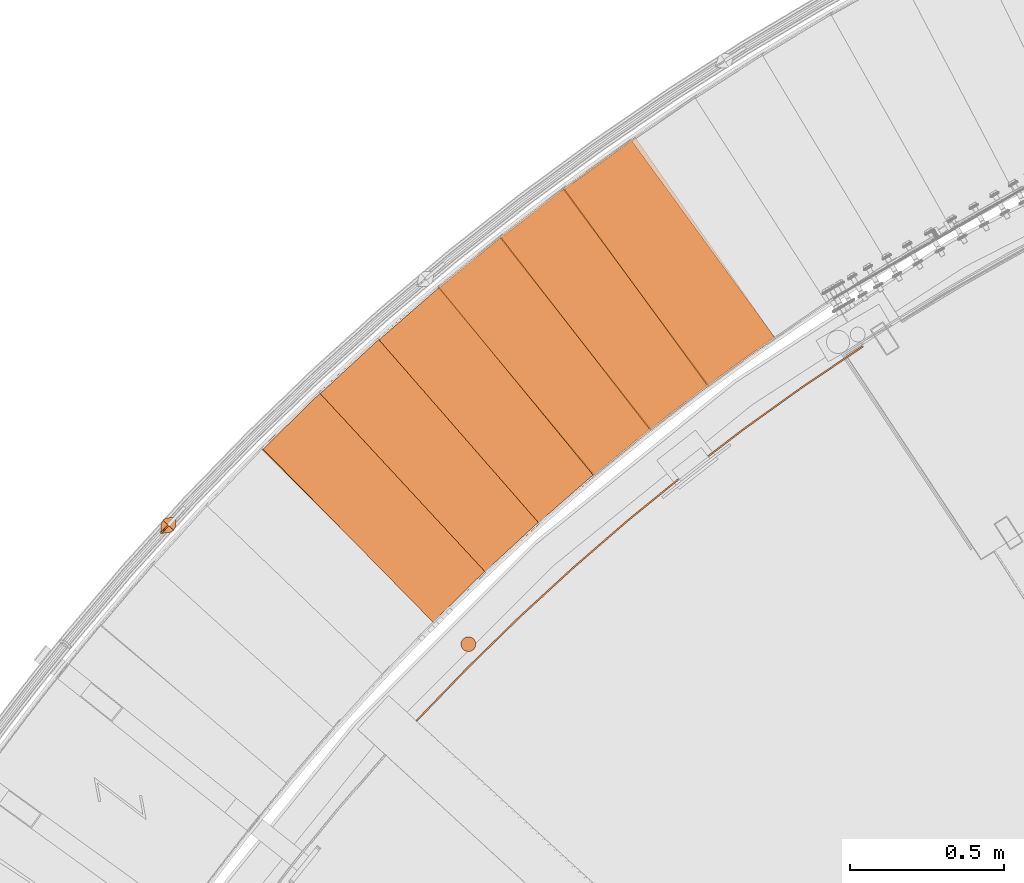
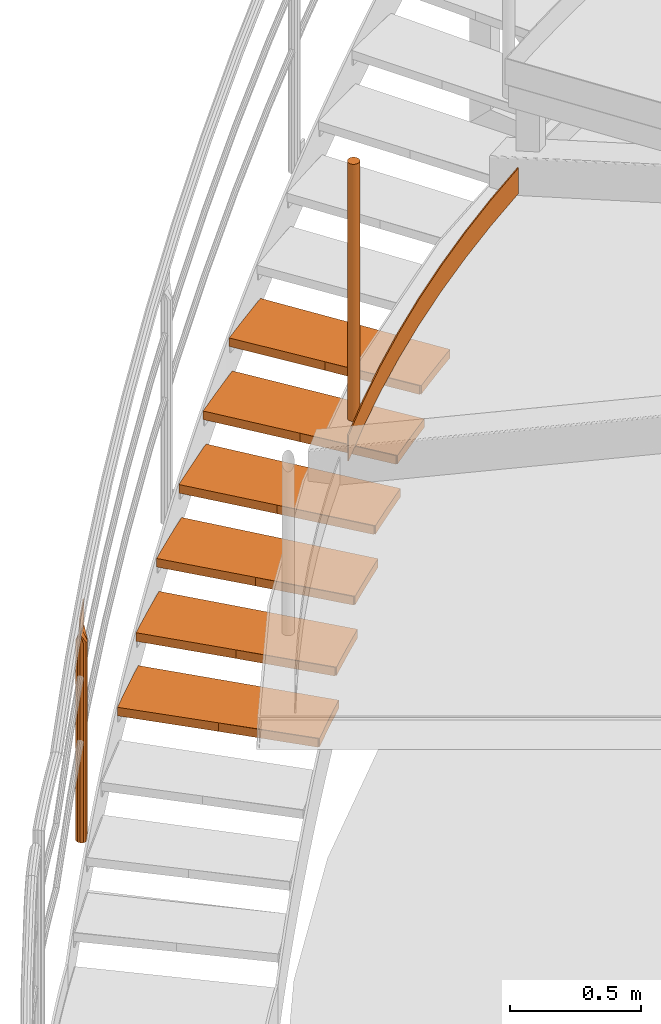
# One storey, part 32 of 126: 15 proxies.
"""IFC2X3 building model written with IfcOpenShell, lengths in millimetres."""

from ifc_helpers import new_model, si_unit, origin, origin_with_axes, place, context, project, spatial, faceted_brep, material, element, save


model = new_model("IFC2X3")

# Units and contexts
context_of_model_1 = context(None, 3, precision=0.1, world=origin())
context_of_model_2 = context(None, 3, precision=0.1, world=origin())
ifc_project = project(units=[si_unit("LENGTHUNIT", "METRE", prefix="MILLI"), si_unit("AREAUNIT", "SQUARE_METRE", prefix="CENTI"), si_unit("VOLUMEUNIT", "CUBIC_METRE", prefix="CENTI"), si_unit("MASSUNIT", "GRAM", prefix="KILO")], contexts=[context_of_model_1, context_of_model_2])

# Site, building, storey
site_placement = place(None, origin_with_axes())
site = spatial("IfcSite", under=ifc_project, at=site_placement, CompositionType="ELEMENT")
building_placement = place(site_placement, origin_with_axes())
building = spatial("IfcBuilding", under=site, at=building_placement, CompositionType="ELEMENT")
storey_placement = place(building_placement, origin_with_axes())
storey = spatial("IfcBuildingStorey", under=building, at=storey_placement, CompositionType="ELEMENT")

# Proxies
ifc_material_1 = material(Name="STAHL")
proxy_1_placement = place(storey_placement, origin_with_axes())
element("IfcBuildingElementProxy", 1, at=proxy_1_placement, inside=storey, material=ifc_material_1, Name="profile", context=context_of_model_2, shape_type="Brep", body=[
    faceted_brep([(2471.5, 13605.4, 11706.0), (2471.5, 13605.4, 10506.0), (2470.8, 13611.2, 10506.0), (2470.8, 13611.2, 11706.0), (2468.7, 13616.7, 10506.0), (2468.7, 13616.7, 11706.0), (2465.4, 13621.4, 10506.0), (2465.4, 13621.4, 11706.0), (2461.1, 13625.3, 10506.0), (2461.1, 13625.3, 11706.0), (2455.9, 13628.0, 10506.0), (2455.9, 13628.0, 11706.0), (2450.3, 13629.4, 10506.0), (2450.3, 13629.4, 11706.0), (2444.5, 13629.4, 10506.0), (2444.5, 13629.4, 11706.0), (2438.8, 13628.0, 10506.0), (2438.8, 13628.0, 11706.0), (2433.6, 13625.3, 10506.0), (2433.6, 13625.3, 11706.0), (2429.3, 13621.4, 10506.0), (2429.3, 13621.4, 11706.0), (2426.0, 13616.7, 10506.0), (2426.0, 13616.7, 11706.0), (2423.9, 13611.2, 10506.0), (2423.9, 13611.2, 11706.0), (2423.2, 13605.4, 10506.0), (2423.2, 13605.4, 11706.0), (2423.9, 13599.6, 10506.0), (2423.9, 13599.6, 11706.0), (2426.0, 13594.2, 10506.0), (2426.0, 13594.2, 11706.0), (2429.3, 13589.4, 10506.0), (2429.3, 13589.4, 11706.0), (2433.6, 13585.6, 10506.0), (2433.6, 13585.6, 11706.0), (2438.8, 13582.8, 10506.0), (2438.8, 13582.8, 11706.0), (2444.5, 13581.5, 10506.0), (2444.5, 13581.5, 11706.0), (2450.3, 13581.5, 10506.0), (2450.3, 13581.5, 11706.0), (2455.9, 13582.8, 10506.0), (2455.9, 13582.8, 11706.0), (2461.1, 13585.6, 10506.0), (2461.1, 13585.6, 11706.0), (2465.4, 13589.4, 10506.0), (2465.4, 13589.4, 11706.0), (2468.7, 13594.2, 10506.0), (2468.7, 13594.2, 11706.0), (2470.8, 13599.6, 10506.0), (2470.8, 13599.6, 11706.0)], [[[0, 1, 2, 3]], [[3, 2, 4, 5]], [[5, 4, 6, 7]], [[7, 6, 8, 9]], [[9, 8, 10, 11]], [[11, 10, 12, 13]], [[13, 12, 14, 15]], [[15, 14, 16, 17]], [[17, 16, 18, 19]], [[19, 18, 20, 21]], [[21, 20, 22, 23]], [[23, 22, 24, 25]], [[25, 24, 26, 27]], [[27, 26, 28, 29]], [[29, 28, 30, 31]], [[31, 30, 32, 33]], [[33, 32, 34, 35]], [[35, 34, 36, 37]], [[37, 36, 38, 39]], [[39, 38, 40, 41]], [[41, 40, 42, 43]], [[43, 42, 44, 45]], [[45, 44, 46, 47]], [[47, 46, 48, 49]], [[49, 48, 50, 51]], [[51, 50, 1, 0]], [[39, 41, 43, 45, 47, 49, 51, 0, 3, 5, 7, 9, 11, 13, 15, 17, 19, 21, 23, 25, 27, 29, 31, 33, 35, 37]], [[38, 36, 34, 32, 30, 28, 26, 24, 22, 20, 18, 16, 14, 12, 10, 8, 6, 4, 2, 1, 50, 48, 46, 44, 42, 40]]]),
])
proxy_2_placement = place(storey_placement, origin_with_axes())
element("IfcBuildingElementProxy", 2, at=proxy_2_placement, inside=storey, material=ifc_material_1, Name="profile", context=context_of_model_2, shape_type="Brep", body=[
    faceted_brep([(2276.1, 13357.0, 10516.0), (2276.1, 13357.0, 10636.0), (2441.2, 13528.3, 10636.0), (2611.3, 13694.6, 10636.0), (2786.5, 13855.7, 10636.0), (2966.4, 14011.3, 10636.0), (3151.0, 14161.4, 10636.0), (3340.0, 14305.9, 10636.0), (3533.4, 14444.5, 10636.0), (3730.8, 14577.3, 10636.0), (3730.8, 14577.3, 10516.0), (3533.4, 14444.5, 10516.0), (3340.0, 14305.9, 10516.0), (3151.0, 14161.4, 10516.0), (2966.4, 14011.3, 10516.0), (2786.5, 13855.7, 10516.0), (2611.3, 13694.6, 10516.0), (2441.2, 13528.3, 10516.0), (2279.8, 13353.5, 10636.0), (2444.7, 13524.8, 10636.0), (2614.8, 13691.0, 10636.0), (2789.8, 13851.9, 10636.0), (2969.6, 14007.5, 10636.0), (3154.1, 14157.5, 10636.0), (3343.0, 14301.9, 10636.0), (3536.2, 14440.4, 10636.0), (3733.5, 14573.1, 10636.0), (2279.8, 13353.5, 10516.0), (2444.7, 13524.8, 10516.0), (2614.8, 13691.0, 10516.0), (2789.8, 13851.9, 10516.0), (2969.6, 14007.5, 10516.0), (3154.1, 14157.5, 10516.0), (3343.0, 14301.9, 10516.0), (3536.2, 14440.4, 10516.0), (3733.5, 14573.1, 10516.0)], [[[0, 1, 2, 3, 4, 5, 6, 7, 8, 9, 10, 11, 12, 13, 14, 15, 16, 17]], [[18, 19, 20, 21, 22, 23, 24, 25, 26, 9, 8, 7, 6, 5, 4, 3, 2, 1]], [[18, 27, 28, 29, 30, 31, 32, 33, 34, 35, 26, 25, 24, 23, 22, 21, 20, 19]], [[27, 0, 17, 16, 15, 14, 13, 12, 11, 10, 35, 34, 33, 32, 31, 30, 29, 28]], [[18, 1, 0, 27]], [[26, 35, 10, 9]]]),
])
ifc_material_2 = material(Name="HOLZ")
proxy_3_placement = place(storey_placement, origin_with_axes())
element("IfcBuildingElementProxy", 3, at=proxy_3_placement, inside=storey, material=ifc_material_2, context=context_of_model_2, shape_type="Brep", body=[
    faceted_brep([(1980.7562, 14443.01, 9006.725), (1961.5624, 14424.996, 9006.725), (1942.4226, 14406.925, 9006.725), (1923.3367, 14388.797, 9006.725), (1904.3051, 14370.612, 9006.725), (1885.3279, 14352.37, 9006.725), (1866.4052, 14334.071, 9006.725), (1847.5372, 14315.716, 9006.725), (1828.7241, 14297.305, 9006.725), (1809.966, 14278.838, 9006.725), (1791.2632, 14260.315, 9006.725), (1772.6157, 14241.736, 9006.725), (2338.1037, 13675.853, 9006.725), (2356.9507, 13694.625, 9006.725), (2375.8598, 13713.333, 9006.725), (2394.831, 13731.979, 9006.725), (2413.8639, 13750.562, 9006.725), (2432.9584, 13769.082, 9006.725), (2452.1142, 13787.538, 9006.725), (2471.3311, 13805.931, 9006.725), (2490.609, 13824.259, 9006.725), (2509.9475, 13842.524, 9006.725), (2529.3466, 13860.724, 9006.725), (1980.7562, 14443.01, 8966.725), (2529.3466, 13860.724, 8966.725), (2509.9475, 13842.524, 8966.725), (2490.609, 13824.259, 8966.725), (2471.3311, 13805.931, 8966.725), (2452.1142, 13787.538, 8966.725), (2432.9584, 13769.082, 8966.725), (2413.8639, 13750.562, 8966.725), (2394.831, 13731.979, 8966.725), (2375.8598, 13713.333, 8966.725), (2356.9507, 13694.625, 8966.725), (2338.1037, 13675.853, 8966.725), (1772.6157, 14241.736, 8966.725), (1791.2632, 14260.315, 8966.725), (1809.966, 14278.838, 8966.725), (1828.7241, 14297.305, 8966.725), (1847.5372, 14315.716, 8966.725), (1866.4052, 14334.071, 8966.725), (1885.3279, 14352.37, 8966.725), (1904.3051, 14370.612, 8966.725), (1923.3367, 14388.797, 8966.725), (1942.4226, 14406.925, 8966.725), (1961.5624, 14424.996, 8966.725)], [[[0, 1, 2, 3, 4, 5, 6, 7, 8, 9, 10, 11, 12, 13, 14, 15, 16, 17, 18, 19, 20, 21, 22]], [[23, 24, 25, 26, 27, 28, 29, 30, 31, 32, 33, 34, 35, 36, 37, 38, 39, 40, 41, 42, 43, 44, 45]], [[0, 23, 45, 1]], [[1, 45, 44, 2]], [[2, 44, 43, 3]], [[3, 43, 42, 4]], [[4, 42, 41, 5]], [[5, 41, 40, 6]], [[6, 40, 39, 7]], [[7, 39, 38, 8]], [[8, 38, 37, 9]], [[9, 37, 36, 10]], [[10, 36, 35, 11]], [[11, 35, 34, 12]], [[12, 34, 33, 13]], [[13, 33, 32, 14]], [[14, 32, 31, 15]], [[15, 31, 30, 16]], [[16, 30, 29, 17]], [[17, 29, 28, 18]], [[18, 28, 27, 19]], [[19, 27, 26, 20]], [[20, 26, 25, 21]], [[21, 25, 24, 22]], [[22, 24, 23, 0]]]),
])
proxy_4_placement = place(storey_placement, origin_with_axes())
element("IfcBuildingElementProxy", 4, at=proxy_4_placement, inside=storey, material=ifc_material_2, context=context_of_model_2, shape_type="Brep", body=[
    faceted_brep([(2172.8601, 14617.536, 9179.9312), (2153.1445, 14600.095, 9179.9312), (2133.481, 14582.595, 9179.9312), (2113.8699, 14565.036, 9179.9312), (2094.3112, 14547.419, 9179.9312), (2074.8053, 14529.744, 9179.9312), (2055.3522, 14512.01, 9179.9312), (2035.9521, 14494.218, 9179.9312), (2016.6053, 14476.369, 9179.9312), (1997.3118, 14458.462, 9179.9312), (1978.0718, 14440.497, 9179.9312), (1958.8856, 14422.475, 9179.9312), (2507.4726, 13840.193, 9179.9312), (2526.8639, 13858.402, 9179.9312), (2546.3156, 13876.546, 9179.9312), (2565.8273, 13894.626, 9179.9312), (2585.399, 13912.64, 9179.9312), (2605.0303, 13930.59, 9179.9312), (2624.721, 13948.474, 9179.9312), (2644.471, 13966.293, 9179.9312), (2664.28, 13984.047, 9179.9312), (2684.1477, 14001.734, 9179.9312), (2704.0741, 14019.356, 9179.9312), (2172.8601, 14617.536, 9139.9312), (2704.0741, 14019.356, 9139.9312), (2684.1477, 14001.734, 9139.9312), (2664.28, 13984.047, 9139.9312), (2644.471, 13966.293, 9139.9312), (2624.721, 13948.474, 9139.9312), (2605.0303, 13930.59, 9139.9312), (2585.399, 13912.64, 9139.9312), (2565.8273, 13894.626, 9139.9312), (2546.3156, 13876.546, 9139.9312), (2526.8639, 13858.402, 9139.9312), (2507.4726, 13840.193, 9139.9312), (1958.8856, 14422.475, 9139.9312), (1978.0718, 14440.497, 9139.9312), (1997.3118, 14458.462, 9139.9312), (2016.6053, 14476.369, 9139.9312), (2035.9521, 14494.218, 9139.9312), (2055.3522, 14512.01, 9139.9312), (2074.8053, 14529.744, 9139.9312), (2094.3112, 14547.419, 9139.9312), (2113.8699, 14565.036, 9139.9312), (2133.481, 14582.595, 9139.9312), (2153.1445, 14600.095, 9139.9312)], [[[0, 1, 2, 3, 4, 5, 6, 7, 8, 9, 10, 11, 12, 13, 14, 15, 16, 17, 18, 19, 20, 21, 22]], [[23, 24, 25, 26, 27, 28, 29, 30, 31, 32, 33, 34, 35, 36, 37, 38, 39, 40, 41, 42, 43, 44, 45]], [[0, 23, 45, 1]], [[1, 45, 44, 2]], [[2, 44, 43, 3]], [[3, 43, 42, 4]], [[4, 42, 41, 5]], [[5, 41, 40, 6]], [[6, 40, 39, 7]], [[7, 39, 38, 8]], [[8, 38, 37, 9]], [[9, 37, 36, 10]], [[10, 36, 35, 11]], [[11, 35, 34, 12]], [[12, 34, 33, 13]], [[13, 33, 32, 14]], [[14, 32, 31, 15]], [[15, 31, 30, 16]], [[16, 30, 29, 17]], [[17, 29, 28, 18]], [[18, 28, 27, 19]], [[19, 27, 26, 20]], [[20, 26, 25, 21]], [[21, 25, 24, 22]], [[22, 24, 23, 0]]]),
])
proxy_5_placement = place(storey_placement, origin_with_axes())
element("IfcBuildingElementProxy", 5, at=proxy_5_placement, inside=storey, material=ifc_material_2, context=context_of_model_2, shape_type="Brep", body=[
    faceted_brep([(2370.0177, 14786.332, 9353.1375), (2349.7973, 14769.478, 9353.1375), (2329.6272, 14752.565, 9353.1375), (2309.5078, 14735.591, 9353.1375), (2289.4391, 14718.557, 9353.1375), (2269.4213, 14701.464, 9353.1375), (2249.4547, 14684.31, 9353.1375), (2229.5394, 14667.097, 9353.1375), (2209.6755, 14649.825, 9353.1375), (2189.8633, 14632.494, 9353.1375), (2170.103, 14615.103, 9353.1375), (2150.3946, 14597.654, 9353.1375), (2681.6053, 13999.477, 9353.1375), (2701.5241, 14017.107, 9353.1375), (2721.5014, 14034.671, 9353.1375), (2741.5369, 14052.168, 9353.1375), (2761.6302, 14069.599, 9353.1375), (2781.7813, 14086.963, 9353.1375), (2801.99, 14104.26, 9353.1375), (2822.2559, 14121.49, 9353.1375), (2842.5788, 14138.653, 9353.1375), (2862.9586, 14155.748, 9353.1375), (2883.395, 14172.775, 9353.1375), (2370.0177, 14786.332, 9313.1375), (2883.395, 14172.775, 9313.1375), (2862.9586, 14155.748, 9313.1375), (2842.5788, 14138.653, 9313.1375), (2822.2559, 14121.49, 9313.1375), (2801.99, 14104.26, 9313.1375), (2781.7813, 14086.963, 9313.1375), (2761.6302, 14069.599, 9313.1375), (2741.5369, 14052.168, 9313.1375), (2721.5014, 14034.671, 9313.1375), (2701.5241, 14017.107, 9313.1375), (2681.6053, 13999.477, 9313.1375), (2150.3946, 14597.654, 9313.1375), (2170.103, 14615.103, 9313.1375), (2189.8633, 14632.494, 9313.1375), (2209.6755, 14649.825, 9313.1375), (2229.5394, 14667.097, 9313.1375), (2249.4547, 14684.31, 9313.1375), (2269.4213, 14701.464, 9313.1375), (2289.4391, 14718.557, 9313.1375), (2309.5078, 14735.591, 9313.1375), (2329.6272, 14752.565, 9313.1375), (2349.7973, 14769.478, 9313.1375)], [[[0, 1, 2, 3, 4, 5, 6, 7, 8, 9, 10, 11, 12, 13, 14, 15, 16, 17, 18, 19, 20, 21, 22]], [[23, 24, 25, 26, 27, 28, 29, 30, 31, 32, 33, 34, 35, 36, 37, 38, 39, 40, 41, 42, 43, 44, 45]], [[0, 23, 45, 1]], [[1, 45, 44, 2]], [[2, 44, 43, 3]], [[3, 43, 42, 4]], [[4, 42, 41, 5]], [[5, 41, 40, 6]], [[6, 40, 39, 7]], [[7, 39, 38, 8]], [[8, 38, 37, 9]], [[9, 37, 36, 10]], [[10, 36, 35, 11]], [[11, 35, 34, 12]], [[12, 34, 33, 13]], [[13, 33, 32, 14]], [[14, 32, 31, 15]], [[15, 31, 30, 16]], [[16, 30, 29, 17]], [[17, 29, 28, 18]], [[18, 28, 27, 19]], [[19, 27, 26, 20]], [[20, 26, 25, 21]], [[21, 25, 24, 22]], [[22, 24, 23, 0]]]),
])
proxy_6_placement = place(storey_placement, origin_with_axes())
element("IfcBuildingElementProxy", 6, at=proxy_6_placement, inside=storey, material=ifc_material_2, context=context_of_model_2, shape_type="Brep", body=[
    faceted_brep([(2572.0582, 14949.252, 9526.3438), (2551.3505, 14933.001, 9526.3438), (2530.6913, 14916.688, 9526.3438), (2510.081, 14900.314, 9526.3438), (2489.5196, 14883.878, 9526.3438), (2469.0074, 14867.381, 9526.3438), (2448.5446, 14850.823, 9526.3438), (2428.1312, 14834.204, 9526.3438), (2407.7676, 14817.523, 9526.3438), (2387.4539, 14800.783, 9526.3438), (2367.1902, 14783.981, 9526.3438), (2346.9768, 14767.12, 9526.3438), (2860.3508, 14153.567, 9526.3438), (2880.7799, 14170.603, 9526.3438), (2901.2655, 14187.571, 9526.3438), (2921.8073, 14204.471, 9526.3438), (2942.405, 14221.303, 9526.3438), (2963.0585, 14238.066, 9526.3438), (2983.7675, 14254.761, 9526.3438), (3004.5317, 14271.387, 9526.3438), (3025.351, 14287.944, 9526.3438), (3046.2251, 14304.432, 9526.3438), (3067.1538, 14320.85, 9526.3438), (2572.0582, 14949.252, 9486.3438), (3067.1538, 14320.85, 9486.3438), (3046.2251, 14304.432, 9486.3438), (3025.351, 14287.944, 9486.3438), (3004.5317, 14271.387, 9486.3438), (2983.7675, 14254.761, 9486.3438), (2963.0585, 14238.066, 9486.3438), (2942.405, 14221.303, 9486.3438), (2921.8073, 14204.471, 9486.3438), (2901.2655, 14187.571, 9486.3438), (2880.7799, 14170.603, 9486.3438), (2860.3508, 14153.567, 9486.3438), (2346.9768, 14767.12, 9486.3438), (2367.1902, 14783.981, 9486.3438), (2387.4539, 14800.783, 9486.3438), (2407.7676, 14817.523, 9486.3438), (2428.1312, 14834.204, 9486.3438), (2448.5446, 14850.823, 9486.3438), (2469.0074, 14867.381, 9486.3438), (2489.5196, 14883.878, 9486.3438), (2510.081, 14900.314, 9486.3438), (2530.6913, 14916.688, 9486.3438), (2551.3505, 14933.001, 9486.3438)], [[[0, 1, 2, 3, 4, 5, 6, 7, 8, 9, 10, 11, 12, 13, 14, 15, 16, 17, 18, 19, 20, 21, 22]], [[23, 24, 25, 26, 27, 28, 29, 30, 31, 32, 33, 34, 35, 36, 37, 38, 39, 40, 41, 42, 43, 44, 45]], [[0, 23, 45, 1]], [[1, 45, 44, 2]], [[2, 44, 43, 3]], [[3, 43, 42, 4]], [[4, 42, 41, 5]], [[5, 41, 40, 6]], [[6, 40, 39, 7]], [[7, 39, 38, 8]], [[8, 38, 37, 9]], [[9, 37, 36, 10]], [[10, 36, 35, 11]], [[11, 35, 34, 12]], [[12, 34, 33, 13]], [[13, 33, 32, 14]], [[14, 32, 31, 15]], [[15, 31, 30, 16]], [[16, 30, 29, 17]], [[17, 29, 28, 18]], [[18, 28, 27, 19]], [[19, 27, 26, 20]], [[20, 26, 25, 21]], [[21, 25, 24, 22]], [[22, 24, 23, 0]]]),
])
proxy_7_placement = place(storey_placement, origin_with_axes())
element("IfcBuildingElementProxy", 7, at=proxy_7_placement, inside=storey, material=ifc_material_2, context=context_of_model_2, shape_type="Brep", body=[
    faceted_brep([(2778.8064, 15106.154, 9699.55), (2757.6294, 15090.52, 9699.55), (2736.499, 15074.822, 9699.55), (2715.4157, 15059.062, 9699.55), (2694.3795, 15043.238, 9699.55), (2673.3906, 15027.352, 9699.55), (2652.4492, 15011.403, 9699.55), (2631.5556, 14995.392, 9699.55), (2610.7098, 14979.319, 9699.55), (2589.9121, 14963.183, 9699.55), (2569.1627, 14946.985, 9699.55), (2548.4618, 14930.726, 9699.55), (3043.5543, 14302.328, 9699.55), (3064.476, 14318.756, 9699.55), (3085.4521, 14335.113, 9699.55), (3106.4824, 14351.402, 9699.55), (3127.5667, 14367.62, 9699.55), (3148.7046, 14383.768, 9699.55), (3169.896, 14399.846, 9699.55), (3191.1406, 14415.854, 9699.55), (3212.4382, 14431.791, 9699.55), (3233.7886, 14447.657, 9699.55), (3255.1915, 14463.452, 9699.55), (2778.8064, 15106.154, 9659.55), (3255.1915, 14463.452, 9659.55), (3233.7886, 14447.657, 9659.55), (3212.4382, 14431.791, 9659.55), (3191.1406, 14415.854, 9659.55), (3169.896, 14399.846, 9659.55), (3148.7046, 14383.768, 9659.55), (3127.5667, 14367.62, 9659.55), (3106.4824, 14351.402, 9659.55), (3085.4521, 14335.113, 9659.55), (3064.476, 14318.756, 9659.55), (3043.5543, 14302.328, 9659.55), (2548.4618, 14930.726, 9659.55), (2569.1627, 14946.985, 9659.55), (2589.9121, 14963.183, 9659.55), (2610.7098, 14979.319, 9659.55), (2631.5556, 14995.392, 9659.55), (2652.4492, 15011.403, 9659.55), (2673.3906, 15027.352, 9659.55), (2694.3795, 15043.238, 9659.55), (2715.4157, 15059.062, 9659.55), (2736.499, 15074.822, 9659.55), (2757.6294, 15090.52, 9659.55)], [[[0, 1, 2, 3, 4, 5, 6, 7, 8, 9, 10, 11, 12, 13, 14, 15, 16, 17, 18, 19, 20, 21, 22]], [[23, 24, 25, 26, 27, 28, 29, 30, 31, 32, 33, 34, 35, 36, 37, 38, 39, 40, 41, 42, 43, 44, 45]], [[0, 23, 45, 1]], [[1, 45, 44, 2]], [[2, 44, 43, 3]], [[3, 43, 42, 4]], [[4, 42, 41, 5]], [[5, 41, 40, 6]], [[6, 40, 39, 7]], [[7, 39, 38, 8]], [[8, 38, 37, 9]], [[9, 37, 36, 10]], [[10, 36, 35, 11]], [[11, 35, 34, 12]], [[12, 34, 33, 13]], [[13, 33, 32, 14]], [[14, 32, 31, 15]], [[15, 31, 30, 16]], [[16, 30, 29, 17]], [[17, 29, 28, 18]], [[18, 28, 27, 19]], [[19, 27, 26, 20]], [[20, 26, 25, 21]], [[21, 25, 24, 22]], [[22, 24, 23, 0]]]),
])
proxy_8_placement = place(storey_placement, origin_with_axes())
element("IfcBuildingElementProxy", 8, at=proxy_8_placement, inside=storey, material=ifc_material_2, context=context_of_model_2, shape_type="Brep", body=[
    faceted_brep([(2990.0833, 15256.903, 9872.7562), (2968.4552, 15241.899, 9872.7562), (2946.872, 15226.83, 9872.7562), (2925.3339, 15211.697, 9872.7562), (2903.8411, 15196.5, 9872.7562), (2882.3937, 15181.238, 9872.7562), (2860.992, 15165.913, 9872.7562), (2839.6361, 15150.523, 9872.7562), (2818.3263, 15135.07, 9872.7562), (2797.0627, 15119.554, 9872.7562), (2775.8455, 15103.974, 9872.7562), (2754.6749, 15088.331, 9872.7562), (3231.057, 14445.633, 9872.7562), (3252.4532, 14461.438, 9872.7562), (3273.9017, 14477.171, 9872.7562), (3295.4023, 14492.833, 9872.7562), (3316.9547, 14508.424, 9872.7562), (3338.5588, 14523.943, 9872.7562), (3360.2142, 14539.39, 9872.7562), (3381.9208, 14554.765, 9872.7562), (3403.6783, 14570.069, 9872.7562), (3425.4864, 14585.3, 9872.7562), (3447.3449, 14600.458, 9872.7562), (2990.0833, 15256.903, 9832.7562), (3447.3449, 14600.458, 9832.7562), (3425.4864, 14585.3, 9832.7562), (3403.6783, 14570.069, 9832.7562), (3381.9208, 14554.765, 9832.7562), (3360.2142, 14539.39, 9832.7562), (3338.5588, 14523.943, 9832.7562), (3316.9547, 14508.424, 9832.7562), (3295.4023, 14492.833, 9832.7562), (3273.9017, 14477.171, 9832.7562), (3252.4532, 14461.438, 9832.7562), (3231.057, 14445.633, 9832.7562), (2754.6749, 15088.331, 9832.7562), (2775.8455, 15103.974, 9832.7562), (2797.0627, 15119.554, 9832.7562), (2818.3263, 15135.07, 9832.7562), (2839.6361, 15150.523, 9832.7562), (2860.992, 15165.913, 9832.7562), (2882.3937, 15181.238, 9832.7562), (2903.8411, 15196.5, 9832.7562), (2925.3339, 15211.697, 9832.7562), (2946.872, 15226.83, 9832.7562), (2968.4552, 15241.899, 9832.7562)], [[[0, 1, 2, 3, 4, 5, 6, 7, 8, 9, 10, 11, 12, 13, 14, 15, 16, 17, 18, 19, 20, 21, 22]], [[23, 24, 25, 26, 27, 28, 29, 30, 31, 32, 33, 34, 35, 36, 37, 38, 39, 40, 41, 42, 43, 44, 45]], [[0, 23, 45, 1]], [[1, 45, 44, 2]], [[2, 44, 43, 3]], [[3, 43, 42, 4]], [[4, 42, 41, 5]], [[5, 41, 40, 6]], [[6, 40, 39, 7]], [[7, 39, 38, 8]], [[8, 38, 37, 9]], [[9, 37, 36, 10]], [[10, 36, 35, 11]], [[11, 35, 34, 12]], [[12, 34, 33, 13]], [[13, 33, 32, 14]], [[14, 32, 31, 15]], [[15, 31, 30, 16]], [[16, 30, 29, 17]], [[17, 29, 28, 18]], [[18, 28, 27, 19]], [[19, 27, 26, 20]], [[20, 26, 25, 21]], [[21, 25, 24, 22]], [[22, 24, 23, 0]]]),
])
ifc_material_3 = material(Name="S235JRG2")
proxy_9_placement = place(storey_placement, origin_with_axes())
element("IfcBuildingElementProxy", 9, at=proxy_9_placement, inside=storey, material=ifc_material_3, context=context_of_model_2, shape_type="Brep", body=[
    faceted_brep([(1778.5969, 14240.623, 8966.59), (1778.5969, 14240.623, 9006.59), (1971.2404, 14429.802, 9006.59), (1971.2404, 14429.802, 8966.59), (2332.1188, 13676.962, 8966.59), (2524.7624, 13866.141, 8966.59), (2524.7624, 13866.141, 9006.59), (2332.1188, 13676.962, 9006.59)], [[[0, 1, 2, 3]], [[4, 5, 6, 7]], [[0, 4, 7, 1]], [[1, 7, 6, 2]], [[2, 6, 5, 3]], [[3, 5, 4, 0]]]),
])
proxy_10_placement = place(storey_placement, origin_with_axes())
element("IfcBuildingElementProxy", 10, at=proxy_10_placement, inside=storey, material=ifc_material_3, context=context_of_model_2, shape_type="Brep", body=[
    faceted_brep([(1964.8309, 14421.187, 9139.75), (1964.8309, 14421.187, 9179.75), (2162.9591, 14604.613, 9179.75), (2162.9591, 14604.613, 9139.75), (2501.5224, 13841.478, 9139.75), (2699.6507, 14024.904, 9139.75), (2699.6507, 14024.904, 9179.75), (2501.5224, 13841.478, 9179.75)], [[[0, 1, 2, 3]], [[4, 5, 6, 7]], [[0, 4, 7, 1]], [[1, 7, 6, 2]], [[2, 6, 5, 3]], [[3, 5, 4, 0]]]),
])
proxy_11_placement = place(storey_placement, origin_with_axes())
element("IfcBuildingElementProxy", 11, at=proxy_11_placement, inside=storey, material=ifc_material_3, context=context_of_model_2, shape_type="Brep", body=[
    faceted_brep([(2156.2988, 14596.19, 9312.91), (2156.2988, 14596.19, 9352.91), (2359.7401, 14773.705, 9352.91), (2359.7401, 14773.705, 9312.91), (2675.695, 14000.936, 9312.91), (2879.1363, 14178.451, 9312.91), (2879.1363, 14178.451, 9352.91), (2675.695, 14000.936, 9352.91)], [[[0, 1, 2, 3]], [[4, 5, 6, 7]], [[0, 4, 7, 1]], [[1, 7, 6, 2]], [[2, 6, 5, 3]], [[3, 5, 4, 0]]]),
])
proxy_12_placement = place(storey_placement, origin_with_axes())
element("IfcBuildingElementProxy", 12, at=proxy_12_placement, inside=storey, material=ifc_material_3, context=context_of_model_2, shape_type="Brep", body=[
    faceted_brep([(2352.8347, 14765.482, 9486.07), (2352.8347, 14765.482, 9526.07), (2561.4128, 14936.933, 9526.07), (2561.4128, 14936.933, 9486.07), (2854.4854, 14155.198, 9486.07), (3063.0635, 14326.648, 9486.07), (3063.0635, 14326.648, 9526.07), (2854.4854, 14155.198, 9526.07)], [[[0, 1, 2, 3]], [[4, 5, 6, 7]], [[0, 4, 7, 1]], [[1, 7, 6, 2]], [[2, 6, 5, 3]], [[3, 5, 4, 0]]]),
])
proxy_13_placement = place(storey_placement, origin_with_axes())
element("IfcBuildingElementProxy", 13, at=proxy_13_placement, inside=storey, material=ifc_material_3, context=context_of_model_2, shape_type="Brep", body=[
    faceted_brep([(2554.2683, 14928.916, 9659.23), (2554.2683, 14928.916, 9699.23), (2767.8024, 15094.153, 9699.23), (2767.8024, 15094.153, 9659.23), (3037.7389, 14304.131, 9659.23), (3251.273, 14469.368, 9659.23), (3251.273, 14469.368, 9699.23), (3037.7389, 14304.131, 9699.23)], [[[0, 1, 2, 3]], [[4, 5, 6, 7]], [[0, 4, 7, 1]], [[1, 7, 6, 2]], [[2, 6, 5, 3]], [[3, 5, 4, 0]]]),
])
proxy_14_placement = place(storey_placement, origin_with_axes())
element("IfcBuildingElementProxy", 14, at=proxy_14_placement, inside=storey, material=ifc_material_3, context=context_of_model_2, shape_type="Brep", body=[
    faceted_brep([(2760.4251, 15086.351, 9832.39), (2760.4251, 15086.351, 9872.39), (2978.7302, 15245.231, 9872.39), (2978.7302, 15245.231, 9832.39), (3225.2966, 14447.606, 9832.39), (3443.6017, 14606.486, 9832.39), (3443.6017, 14606.486, 9872.39), (3225.2966, 14447.606, 9872.39)], [[[0, 1, 2, 3]], [[4, 5, 6, 7]], [[0, 4, 7, 1]], [[1, 7, 6, 2]], [[2, 6, 5, 3]], [[3, 5, 4, 0]]]),
])
ifc_material_4 = material(Name="1.4462")
proxy_15_placement = place(storey_placement, origin_with_axes())
element("IfcBuildingElementProxy", 15, at=proxy_15_placement, inside=storey, material=ifc_material_4, Name="Pfosten", context=context_of_model_2, shape_type="Brep", body=[
    faceted_brep([(1454.2861, 13974.755, 9576.5549), (1447.5024, 13985.255, 9576.5549), (1447.5024, 13985.255, 8647.6986), (1454.2861, 13974.755, 8647.6976), (1446.8777, 13997.741, 9576.5549), (1446.8777, 13997.741, 8647.7012), (1452.5794, 14008.866, 9576.5549), (1452.5794, 14008.866, 8647.7049), (1463.0796, 14015.649, 9576.5549), (1463.0796, 14015.649, 8647.7085), (1475.565, 14016.274, 9576.5549), (1475.565, 14016.274, 8647.7111), (1486.6899, 14010.572, 9576.5549), (1486.6899, 14010.572, 8647.7121), (1493.4736, 14000.072, 9576.5549), (1493.4736, 14000.072, 8647.7111), (1494.0983, 13987.587, 9576.5549), (1494.0983, 13987.587, 8647.7085), (1488.3967, 13976.462, 9576.5549), (1488.3967, 13976.462, 8647.7049), (1477.8964, 13969.678, 9576.5549), (1477.8964, 13969.678, 8647.7012), (1465.4111, 13969.054, 9576.5549), (1465.4111, 13969.054, 8647.6986), (1491.6542, 13988.112, 9576.5549), (1491.0942, 13999.305, 9576.5549), (1491.0942, 13999.305, 8647.7105), (1491.6542, 13988.112, 8647.7081), (1485.0127, 14008.719, 9576.5549), (1485.0127, 14008.719, 8647.7113), (1475.0394, 14013.83, 9576.5549), (1475.0394, 14013.83, 8647.7105), (1463.8465, 14013.27, 9576.5549), (1463.8465, 14013.27, 8647.7081), (1454.4333, 14007.189, 9576.5549), (1454.4333, 14007.189, 8647.7049), (1449.3218, 13997.215, 9576.5549), (1449.3218, 13997.215, 8647.7016), (1449.8819, 13986.022, 9576.5549), (1449.8819, 13986.022, 8647.6992), (1455.9633, 13976.609, 9576.5549), (1455.9633, 13976.609, 8647.6984), (1465.9366, 13971.498, 9576.5549), (1465.9366, 13971.498, 8647.6992), (1477.1295, 13972.058, 9576.5549), (1477.1295, 13972.058, 8647.7016), (1486.5428, 13978.139, 9576.5549), (1486.5428, 13978.139, 8647.7049), (1445.9954, 13965.591, 9624.8549), (1445.1758, 13967.32, 9624.8549), (1445.8188, 13969.122, 9624.8549), (1468.6341, 13994.341, 9624.8549), (1491.4495, 14019.56, 9624.8549), (1493.1784, 14020.379, 9624.8549), (1494.9806, 14019.736, 9624.8549), (1495.8002, 14018.008, 9624.8549), (1495.1573, 14016.205, 9624.8549), (1472.3419, 13990.987, 9624.8549), (1449.5266, 13965.768, 9624.8549), (1447.7976, 13964.948, 9624.8549), (1493.4517, 14017.748, 9624.8549), (1493.5031, 14017.893, 9624.8549), (1493.4375, 14018.031, 9624.8549), (1493.2934, 14018.082, 9624.8549), (1493.1551, 14018.017, 9624.8549), (1470.3397, 13992.798, 9624.8549), (1447.5244, 13967.579, 9624.8549), (1447.4729, 13967.435, 9624.8549), (1447.5385, 13967.297, 9624.8549), (1447.6827, 13967.245, 9624.8549), (1447.821, 13967.311, 9624.8549), (1470.6363, 13992.53, 9624.8549), (1445.9954, 13965.591, 9695.9782), (1445.1758, 13967.32, 9696.4941), (1445.8188, 13969.122, 9697.7397), (1468.6341, 13994.341, 9721.7022), (1491.4495, 14019.56, 9745.6648), (1493.1784, 14020.379, 9746.9104), (1494.9806, 14019.736, 9747.4263), (1495.8002, 14018.008, 9746.9104), (1495.1573, 14016.205, 9745.6648), (1472.3419, 13990.987, 9721.7022), (1449.5266, 13965.768, 9697.7397), (1447.7976, 13964.948, 9696.4941), (1493.4517, 14017.748, 9745.6648), (1493.5031, 14017.893, 9745.7644), (1493.4375, 14018.031, 9745.8057), (1493.2934, 14018.082, 9745.7644), (1493.1551, 14018.017, 9745.6648), (1470.3397, 13992.798, 9721.7022), (1447.5244, 13967.579, 9697.7397), (1447.4729, 13967.435, 9697.6401), (1447.5385, 13967.297, 9697.5988), (1447.6827, 13967.245, 9697.6401), (1447.821, 13967.311, 9697.7397), (1470.6363, 13992.53, 9721.7022)], [[[0, 1, 2, 3]], [[1, 4, 5, 2]], [[4, 6, 7, 5]], [[6, 8, 9, 7]], [[8, 10, 11, 9]], [[10, 12, 13, 11]], [[12, 14, 15, 13]], [[14, 16, 17, 15]], [[16, 18, 19, 17]], [[18, 20, 21, 19]], [[20, 22, 23, 21]], [[0, 3, 23, 22]], [[24, 25, 26, 27]], [[25, 28, 29, 26]], [[28, 30, 31, 29]], [[30, 32, 33, 31]], [[32, 34, 35, 33]], [[34, 36, 37, 35]], [[36, 38, 39, 37]], [[38, 40, 41, 39]], [[40, 42, 43, 41]], [[42, 44, 45, 43]], [[44, 46, 47, 45]], [[24, 27, 47, 46]], [[0, 48, 49, 1]], [[1, 49, 50, 4]], [[4, 50, 51, 6]], [[6, 51, 52, 8]], [[8, 52, 53, 10]], [[10, 53, 54, 12]], [[12, 54, 55, 14]], [[14, 55, 56, 16]], [[16, 56, 57, 18]], [[18, 57, 58, 20]], [[20, 58, 59, 22]], [[22, 59, 48, 0]], [[24, 60, 61, 25]], [[25, 61, 62, 28]], [[28, 62, 63, 30]], [[30, 63, 64, 32]], [[32, 64, 65, 34]], [[34, 65, 66, 36]], [[36, 66, 67, 38]], [[38, 67, 68, 40]], [[40, 68, 69, 42]], [[42, 69, 70, 44]], [[44, 70, 71, 46]], [[46, 71, 60, 24]], [[48, 72, 73, 49]], [[49, 73, 74, 50]], [[50, 74, 75, 51]], [[51, 75, 76, 52]], [[52, 76, 77, 53]], [[53, 77, 78, 54]], [[54, 78, 79, 55]], [[55, 79, 80, 56]], [[56, 80, 81, 57]], [[57, 81, 82, 58]], [[58, 82, 83, 59]], [[48, 59, 83, 72]], [[60, 84, 85, 61]], [[61, 85, 86, 62]], [[62, 86, 87, 63]], [[63, 87, 88, 64]], [[64, 88, 89, 65]], [[65, 89, 90, 66]], [[66, 90, 91, 67]], [[67, 91, 92, 68]], [[68, 92, 93, 69]], [[69, 93, 94, 70]], [[70, 94, 95, 71]], [[60, 71, 95, 84]], [[7, 9, 11, 13, 15, 17, 19, 21, 23, 3, 2, 5], [26, 29, 31, 33, 35, 37, 39, 41, 43, 45, 47, 27]], [[74, 73, 72, 83, 82, 81, 80, 79, 78, 77, 76, 75], [84, 95, 94, 93, 92, 91, 90, 89, 88, 87, 86, 85]]]),
])

save(model, "model.ifc")
